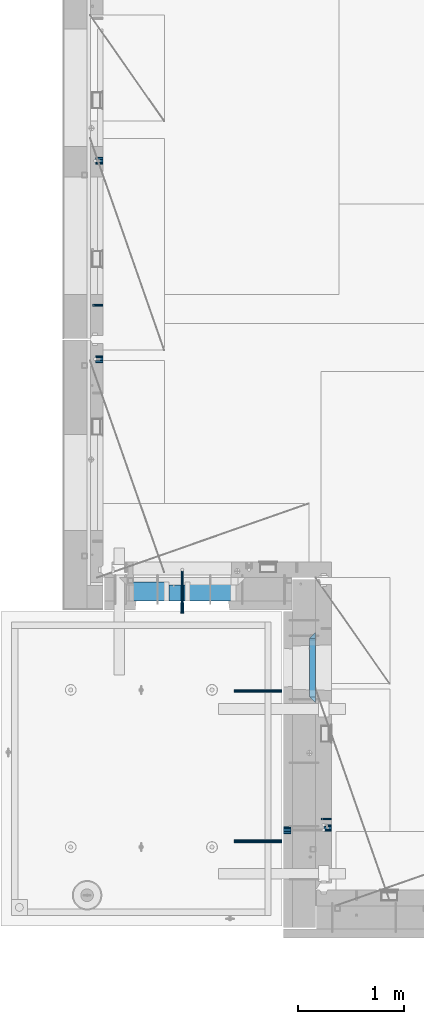
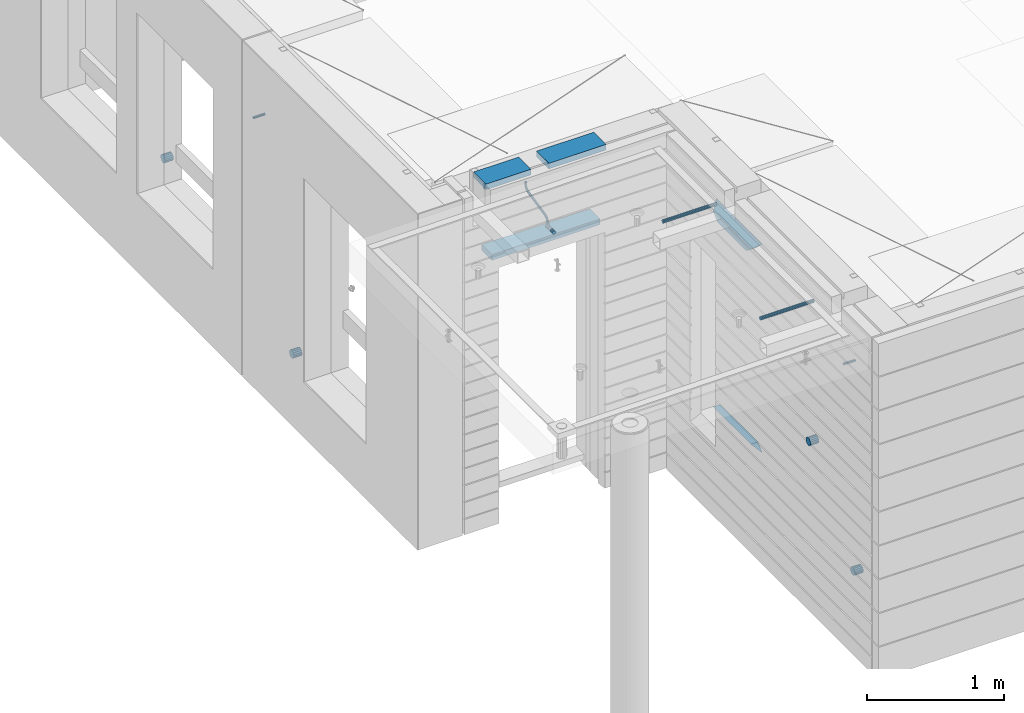
# One storey, part 139 of 349: 16 beams, 9 elements without a shape of their own.
"""IFC2X3 building model written with IfcOpenShell, lengths in millimetres."""

from ifc_helpers import new_model, si_unit, frame, origin_with_axes, place, context, subcontext, project, spatial, faceted_brep, material, type_object, element, aggregate, save


model = new_model("IFC2X3")

# Units and contexts
model_context = context("Model", 3, precision=1e-05, world=origin_with_axes())
body_context = subcontext(model_context, "Body", "Model", "MODEL_VIEW")
ifc_project = project(units=[si_unit("LENGTHUNIT", "METRE", prefix="MILLI"), si_unit("AREAUNIT", "SQUARE_METRE"), si_unit("VOLUMEUNIT", "CUBIC_METRE"), si_unit("MASSUNIT", "GRAM", prefix="KILO"), si_unit("TIMEUNIT", "SECOND"), si_unit("PLANEANGLEUNIT", "RADIAN"), si_unit("SOLIDANGLEUNIT", "STERADIAN"), si_unit("THERMODYNAMICTEMPERATUREUNIT", "DEGREE_CELSIUS"), si_unit("LUMINOUSINTENSITYUNIT", "LUMEN")], contexts=[model_context])

# Site, building, storey
site_placement = place(None, origin_with_axes())
site = spatial("IfcSite", under=ifc_project, at=site_placement, CompositionType="ELEMENT")
building_placement = place(site_placement, origin_with_axes())
building = spatial("IfcBuilding", under=site, at=building_placement, CompositionType="ELEMENT")
storey_placement = place(building_placement, origin_with_axes())
storey = spatial("IfcBuildingStorey", under=building, at=storey_placement, Name="4", CompositionType="ELEMENT", Elevation=0.0)

# Assembly, beam
assembly_1_placement = place(storey_placement, origin_with_axes())
assembly_1 = element("IfcElementAssembly", 1, at=assembly_1_placement, inside=storey, AssemblyPlace="NOTDEFINED", PredefinedType="REINFORCEMENT_UNIT")
ifc_material_1 = material(Name="TIMBER")
beam_type_1 = type_object("IfcBeamType", Name="50X150", PredefinedType="NOTDEFINED")
beam_1_placement = place(assembly_1_placement, frame((8295.00084638596, 10804.9999977209, 93070.0), z_axis=(0.0, 0.0, -1.0), x_axis=(1.0, 0.0, 0.0)))
beam_1 = element("IfcBeam", 2, at=beam_1_placement, type_object=beam_type_1, material=ifc_material_1, ObjectType="50X150", context=body_context, shape_type="Brep", body=[
    faceted_brep([(0.0, 75.0, -25.0), (1.81898940354586e-12, 75.0, 25.0), (909.997711181644, 75.0, 25.0), (909.997711181641, 75.0, -25.0), (1.81898940354586e-12, -75.0000000000009, 25.0), (909.997711181644, -75.0, 25.0), (0.0, -75.0, -25.0), (909.997711181641, -75.0, -25.0)], [[[0, 1, 2, 3]], [[1, 4, 5, 2]], [[4, 6, 7, 5]], [[6, 0, 3, 7]], [[5, 7, 3, 2]], [[6, 4, 1, 0]]]),
])

# Assemblies, beam
assembly_2_placement = place(storey_placement, origin_with_axes())
assembly_2 = element("IfcElementAssembly", 3, at=assembly_2_placement, inside=storey, AssemblyPlace="NOTDEFINED", PredefinedType="REINFORCEMENT_UNIT")
assembly_3_placement = place(assembly_2_placement, origin_with_axes())
assembly_3 = element("IfcElementAssembly", 4, at=assembly_3_placement, Name="Steel Assembly", AssemblyPlace="NOTDEFINED", PredefinedType="RIGID_FRAME")
ifc_material_2 = material(Name="STEEL/Steel_Undefined")
beam_type_2 = type_object("IfcBeamType", PredefinedType="NOTDEFINED")
beam_2_placement = place(assembly_3_placement, frame((10160.0000000031, 8669.99635449804, 92755.0), z_axis=(0.0, -1.0, 0.0), x_axis=(-1.0, 3.00000001838171e-08, 0.0)))
beam_2 = element("IfcBeam", 5, at=beam_2_placement, type_object=beam_type_2, material=ifc_material_2, Name="M16", context=body_context, shape_type="Brep", body=[
    faceted_brep([(0.0, -8.49999999999272, -1.45519152283669e-11), (0.0, -7.36121593215648, 4.24999999998545), (100.000000000262, -7.36121593215648, 4.24999999998545), (100.000000000262, -8.49999999999272, -1.45519152283669e-11), (0.0, -4.24999999998545, 7.36121593216376), (100.000000000262, -4.24999999998545, 7.36121593216376), (0.0, 1.45519152283669e-11, 8.49999999998545), (100.000000000262, 1.45519152283669e-11, 8.49999999998545), (0.0, 4.25000000001455, 7.36121593216376), (100.000000000262, 4.25000000001455, 7.36121593216376), (0.0, 7.36121593217104, 4.24999999998545), (100.000000000262, 7.36121593217104, 4.24999999998545), (0.0, 8.50000000000728, 0.0), (100.000000000262, 8.50000000000728, 0.0), (0.0, 7.36121593217104, -4.25000000001455), (100.000000000262, 7.36121593217104, -4.25000000001455), (0.0, 4.25000000000728, -7.36121593219286), (100.000000000262, 4.25000000000728, -7.36121593219286), (0.0, 7.27595761418343e-12, -8.5), (100.000000000262, 7.27595761418343e-12, -8.5), (0.0, -4.24999999999272, -7.36121593217831), (100.000000000262, -4.24999999999272, -7.36121593217831), (0.0, -7.36121593215648, -4.25), (100.000000000262, -7.36121593215648, -4.25), (0.0, -10.4999999999927, -1.45519152283669e-11), (0.0, -9.09326673972828, -5.25000000001455), (100.000000000262, -9.09326673972828, -5.25000000001455), (100.000000000262, -10.4999999999927, -1.45519152283669e-11), (0.0, -5.24999999998545, -9.09326673974283), (100.000000000262, -5.24999999998545, -9.09326673974283), (0.0, 7.27595761418343e-12, -10.5), (100.000000000262, 7.27595761418343e-12, -10.5), (0.0, 5.25000000001455, -9.09326673975738), (100.000000000262, 5.25000000001455, -9.09326673975738), (0.0, 9.09326673975011, -5.25000000001455), (100.000000000262, 9.09326673975011, -5.25000000001455), (0.0, 10.5000000000073, -1.45519152283669e-11), (100.000000000262, 10.5000000000073, -1.45519152283669e-11), (0.0, 9.09326673975011, 5.25), (100.000000000262, 9.09326673975011, 5.25), (0.0, 5.25000000000728, 9.09326673972828), (100.000000000262, 5.25000000000728, 9.09326673972828), (0.0, 1.45519152283669e-11, 10.4999999999854), (100.000000000262, 1.45519152283669e-11, 10.4999999999854), (0.0, -5.24999999999272, 9.09326673972828), (100.000000000262, -5.24999999999272, 9.09326673972828), (0.0, -9.09326673972828, 5.24999999998545), (100.000000000262, -9.09326673972828, 5.24999999998545)], [[[0, 1, 2, 3]], [[1, 4, 5, 2]], [[4, 6, 7, 5]], [[6, 8, 9, 7]], [[8, 10, 11, 9]], [[10, 12, 13, 11]], [[12, 14, 15, 13]], [[14, 16, 17, 15]], [[16, 18, 19, 17]], [[18, 20, 21, 19]], [[20, 22, 23, 21]], [[22, 0, 3, 23]], [[24, 25, 26, 27]], [[25, 28, 29, 26]], [[28, 30, 31, 29]], [[30, 32, 33, 31]], [[32, 34, 35, 33]], [[34, 36, 37, 35]], [[36, 38, 39, 37]], [[38, 40, 41, 39]], [[40, 42, 43, 41]], [[42, 44, 45, 43]], [[44, 46, 47, 45]], [[46, 24, 27, 47]], [[29, 31, 33, 35, 37, 39, 41, 43, 45, 47, 27, 26], [5, 7, 9, 11, 13, 15, 17, 19, 21, 23, 3, 2]], [[46, 44, 42, 40, 38, 36, 34, 32, 30, 28, 25, 24], [22, 20, 18, 16, 14, 12, 10, 8, 6, 4, 1, 0]]]),
])
aggregate(assembly_3, [beam_2])

assembly_4_placement = place(storey_placement, origin_with_axes())
assembly_4 = element("IfcElementAssembly", 6, at=assembly_4_placement, inside=storey, AssemblyPlace="NOTDEFINED", PredefinedType="REINFORCEMENT_UNIT")
assembly_5_placement = place(assembly_4_placement, origin_with_axes())
assembly_5 = element("IfcElementAssembly", 7, at=assembly_5_placement, Name="Steel Assembly", AssemblyPlace="NOTDEFINED", PredefinedType="RIGID_FRAME")
beam_3_placement = place(assembly_5_placement, frame((7999.99973272466, 13524.9954111548, 92755.0), z_axis=(0.0, -1.0, 0.0), x_axis=(-1.0, 3.00000001838171e-08, 0.0)))
beam_3 = element("IfcBeam", 8, at=beam_3_placement, type_object=beam_type_2, material=ifc_material_2, Name="M16", context=body_context, shape_type="Brep", body=[
    faceted_brep([(0.0, -8.49999999999272, -1.45519152283669e-11), (0.0, -7.36121593215648, 4.24999999998545), (100.000000000262, -7.36121593215648, 4.24999999998545), (100.000000000262, -8.49999999999272, -1.45519152283669e-11), (0.0, -4.24999999998545, 7.36121593216376), (100.000000000262, -4.24999999998545, 7.36121593216376), (0.0, 1.45519152283669e-11, 8.49999999998545), (100.000000000262, 1.45519152283669e-11, 8.49999999998545), (0.0, 4.25000000001455, 7.36121593216376), (100.000000000262, 4.25000000001455, 7.36121593216376), (0.0, 7.36121593217104, 4.24999999998545), (100.000000000262, 7.36121593217104, 4.24999999998545), (0.0, 8.50000000000728, 0.0), (100.000000000262, 8.50000000000728, 0.0), (0.0, 7.36121593217104, -4.25000000001455), (100.000000000262, 7.36121593217104, -4.25000000001455), (0.0, 4.25000000000728, -7.36121593219286), (100.000000000262, 4.25000000000728, -7.36121593219286), (0.0, 7.27595761418343e-12, -8.5), (100.000000000262, 7.27595761418343e-12, -8.5), (0.0, -4.24999999999272, -7.36121593217831), (100.000000000262, -4.24999999999272, -7.36121593217831), (0.0, -7.36121593215648, -4.25), (100.000000000262, -7.36121593215648, -4.25), (0.0, -10.4999999999927, -1.45519152283669e-11), (0.0, -9.09326673972828, -5.25000000001455), (100.000000000262, -9.09326673972828, -5.25000000001455), (100.000000000262, -10.4999999999927, -1.45519152283669e-11), (0.0, -5.24999999998545, -9.09326673974283), (100.000000000262, -5.24999999998545, -9.09326673974283), (0.0, 7.27595761418343e-12, -10.5), (100.000000000262, 7.27595761418343e-12, -10.5), (0.0, 5.25000000001455, -9.09326673975738), (100.000000000262, 5.25000000001455, -9.09326673975738), (0.0, 9.09326673975011, -5.25000000001455), (100.000000000262, 9.09326673975011, -5.25000000001455), (0.0, 10.5000000000073, -1.45519152283669e-11), (100.000000000262, 10.5000000000073, -1.45519152283669e-11), (0.0, 9.09326673975011, 5.25), (100.000000000262, 9.09326673975011, 5.25), (0.0, 5.25000000000728, 9.09326673972828), (100.000000000262, 5.25000000000728, 9.09326673972828), (0.0, 1.45519152283669e-11, 10.4999999999854), (100.000000000262, 1.45519152283669e-11, 10.4999999999854), (0.0, -5.24999999999272, 9.09326673972828), (100.000000000262, -5.24999999999272, 9.09326673972828), (0.0, -9.09326673972828, 5.24999999998545), (100.000000000262, -9.09326673972828, 5.24999999998545)], [[[0, 1, 2, 3]], [[1, 4, 5, 2]], [[4, 6, 7, 5]], [[6, 8, 9, 7]], [[8, 10, 11, 9]], [[10, 12, 13, 11]], [[12, 14, 15, 13]], [[14, 16, 17, 15]], [[16, 18, 19, 17]], [[18, 20, 21, 19]], [[20, 22, 23, 21]], [[22, 0, 3, 23]], [[24, 25, 26, 27]], [[25, 28, 29, 26]], [[28, 30, 31, 29]], [[30, 32, 33, 31]], [[32, 34, 35, 33]], [[34, 36, 37, 35]], [[36, 38, 39, 37]], [[38, 40, 41, 39]], [[40, 42, 43, 41]], [[42, 44, 45, 43]], [[44, 46, 47, 45]], [[46, 24, 27, 47]], [[29, 31, 33, 35, 37, 39, 41, 43, 45, 47, 27, 26], [5, 7, 9, 11, 13, 15, 17, 19, 21, 23, 3, 2]], [[46, 44, 42, 40, 38, 36, 34, 32, 30, 28, 25, 24], [22, 20, 18, 16, 14, 12, 10, 8, 6, 4, 1, 0]]]),
])
aggregate(assembly_5, [beam_3])

# Beam
ifc_material_3 = material()
beam_type_3 = type_object("IfcBeamType", Name="D20", PredefinedType="NOTDEFINED")
beam_4_placement = place(assembly_1_placement, frame((8749.01099987619, 11024.9999999788, 93407.5), z_axis=(-0.000415599999849952, -0.999999913638316, 0.0), x_axis=(-0.000120065999970847, 0.0, -0.999999992792078)))
beam_4 = element("IfcBeam", 9, at=beam_4_placement, type_object=beam_type_3, material=ifc_material_3, Name="JM20", ObjectType="D20", context=body_context, shape_type="Brep", body=[
    faceted_brep([(-0.00120059342589229, -9.99999992792982, -1.81898940354586e-12), (-0.000848598996526562, -7.07106776094588, -7.07106781186667), (20.8232838625408, -7.07356789257938, -7.07106678265518), (20.8229318684025, -10.002500059607, 1.02915510069579e-06), (0.0, 0.0, -10.0), (20.8241329547454, -0.00250013169170415, -9.99999897079033), (0.000849296484375373, 7.07106776086221, -7.07106781186667), (20.8249817580218, 7.06856762922689, -7.07106678265518), (0.00120059338223655, 9.99999992792982, 0.0), (20.8253330549196, 9.99749979629632, 1.0292096703779e-06), (0.000848598952870816, 7.07106776094406, 7.07106781186485), (20.8249810604902, 7.06856762931238, 7.07106884107452), (0.0, 0.0, 10.0), (20.8241319682711, -0.00250013157346984, 10.0000010292097), (-0.000849296528031118, -7.07106776086221, 7.07106781186485), (20.8232831650093, -7.07356789249388, 7.07106884107452), (40.7726384379348, -0.00329752151446883, -6.58672044735795), (39.7990928221261, -7.07432640138177, -3.82422098549978), (37.4482429194322, -10.0031646133011, 2.84466611986682), (35.0971847196925, -7.07413845471456, 9.51339724835998), (34.1231362304388, -0.00303172478197666, 12.2755201487289), (35.0966818461602, 7.06799715509078, 9.51302068687073), (37.4475317487959, 9.9968353670065, 2.84413358148049), (39.798589948623, 7.06780920841811, -3.82459754699994), (56.6134582193044, 7.07017615381483, 5.54543822000414), (58.4514841549535, -0.000808958311608876, 3.2647642042939), (52.1785243256745, 9.99890897559089, 11.0529357620781), (47.7446066006523, 7.06977754058425, 16.5610394651339), (45.909033913209, -0.00137268254729861, 18.8431768828377), (47.7470598488144, -7.07235779467737, 16.562502867102), (52.1819937424152, -10.0010906164425, 11.0550053250008), (56.6159114674811, -7.07195918144498, 5.54690162198131), (69.3564592543262, 7.07539916399401, 19.9729559616771), (71.8492429505422, 0.00468241929229407, 18.4335931317055), (63.3422783694841, 10.0034846953076, 23.6924434484845), (57.3297258917155, 7.07370622078452, 27.4132302674134), (54.8408735180419, 0.00228823604993522, 28.9557299626558), (57.3336572142143, -7.06842850865723, 27.4163671326332), (63.3478380990709, -9.99651403996904, 23.6968796458077), (69.3603905768541, -7.06673556544592, 19.9760928269079), (76.5777462286933, 7.08288398612058, 37.8164513940847), (79.4415723249112, 0.0125518247168657, 37.1939186795262), (69.668627354331, 10.0100419194041, 39.324584867969), (62.7614838343434, 7.07933620645599, 40.8348749661036), (59.9024266654887, 0.00753450659613009, 41.4626142320831), (62.7662527616631, -7.0627976548094, 40.8400815174773), (69.675371634672, -9.98995558832394, 39.3319480425926), (76.5825151560421, -7.05924987514118, 37.8216579454656), (129.308523154614, -6.95261720251074, 279.165101653105), (122.401379637289, -9.88332291525512, 280.675391752207), (132.167580323396, 0.11918449733821, 278.53736238712), (129.303754227207, 7.18951665872737, 279.159895101771), (122.394635352946, 10.1166745919945, 280.668028575839), (115.48749183309, 7.18596887904096, 282.178318674083), (112.628434664337, 0.114167179193828, 282.806057940068), (115.492260760511, -6.95616498219715, 282.183525225417), (137.229133330853, 0.124990099046045, 291.044246086658), (134.740500922577, -6.94638672362635, 292.587289291176), (128.728039615235, -9.87606623611646, 296.308301350005), (122.713767699344, -6.94788191340194, 300.027563864771), (120.220764095546, 0.122875581388143, 301.566383296429), (122.709396503866, 7.19425240406599, 300.02334009195), (128.721857811237, 10.1239319165488, 296.302328033165), (134.736129727069, 7.19574759383795, 292.583065518329), (144.322338774131, 7.20140934720075, 303.436489422069), (146.160972676575, 0.130265372217764, 301.156798210583), (139.887153210904, 10.1305263010836, 308.943580001445), (135.453487538296, 7.20177924807103, 314.452090976518), (133.618522976205, 0.130788491054773, 316.735211326552), (135.457156878736, -6.94035548392276, 314.455520115092), (139.892342441963, -9.86947243781106, 308.948429535751), (144.3260081146, -6.94072538479668, 303.43991856068), (156.971701508781, 7.20585774783103, 310.485308401061), (157.94687002321, 0.134410118034793, 307.72445372366), (154.620179671925, 10.1357074636107, 317.153514265787), (152.26979411245, 7.20769303758607, 323.822926758932), (151.297368814296, 0.137005609693006, 326.586694495105), (152.272537328827, -6.93444202010323, 323.825839817728), (154.624059165726, -9.86429173587385, 317.157633953042), (156.974444725187, -6.93627730985281, 310.488221459855), (171.245024905234, 7.20858667482025, 312.927536511204), (171.245873923646, 0.13695276418548, 309.999971503237), (171.244673387351, 10.1388859125454, 319.998037909079), (171.245025284385, 7.21132092570042, 327.06967187077), (171.245874459855, 0.140819578855371, 329.999971129655), (171.246723478296, -6.93081433178304, 327.072406121697), (171.247074992003, -9.86111357003938, 320.00190472537), (171.246723099146, -6.93354858266321, 312.930270762119), (187.500850232711, -6.93159678041229, 312.930269952591), (187.501202129642, -9.85916176723549, 320.001903914186), (187.50000105724, 0.13890456640911, 309.99997069378), (187.499152038683, 7.21053847703843, 312.927535701752), (187.498800520625, 10.1408377147654, 319.998037099565), (187.499152417557, 7.21327272794042, 327.069671061161), (187.500001593056, 0.142771381122657, 329.999970319972), (187.500850611585, -6.92886252950666, 327.072405311999)], [[[0, 1, 2, 3]], [[1, 4, 5, 2]], [[4, 6, 7, 5]], [[6, 8, 9, 7]], [[8, 10, 11, 9]], [[10, 12, 13, 11]], [[12, 14, 15, 13]], [[14, 0, 3, 15]], [[14, 12, 10, 8, 6, 4, 1, 0]], [[2, 5, 16, 17]], [[3, 2, 17, 18]], [[15, 3, 18, 19]], [[13, 15, 19, 20]], [[11, 13, 20, 21]], [[9, 11, 21, 22]], [[7, 9, 22, 23]], [[5, 7, 23, 16]], [[23, 24, 25, 16]], [[22, 26, 24, 23]], [[21, 27, 26, 22]], [[20, 28, 27, 21]], [[19, 29, 28, 20]], [[18, 30, 29, 19]], [[17, 31, 30, 18]], [[16, 25, 31, 17]], [[24, 32, 33, 25]], [[26, 34, 32, 24]], [[27, 35, 34, 26]], [[28, 36, 35, 27]], [[29, 37, 36, 28]], [[30, 38, 37, 29]], [[31, 39, 38, 30]], [[25, 33, 39, 31]], [[32, 40, 41, 33]], [[34, 42, 40, 32]], [[35, 43, 42, 34]], [[36, 44, 43, 35]], [[37, 45, 44, 36]], [[38, 46, 45, 37]], [[39, 47, 46, 38]], [[33, 41, 47, 39]], [[46, 47, 48, 49]], [[47, 41, 50, 48]], [[41, 40, 51, 50]], [[40, 42, 52, 51]], [[42, 43, 53, 52]], [[43, 44, 54, 53]], [[44, 45, 55, 54]], [[45, 46, 49, 55]], [[48, 50, 56, 57]], [[49, 48, 57, 58]], [[55, 49, 58, 59]], [[54, 55, 59, 60]], [[53, 54, 60, 61]], [[52, 53, 61, 62]], [[51, 52, 62, 63]], [[50, 51, 63, 56]], [[63, 64, 65, 56]], [[62, 66, 64, 63]], [[61, 67, 66, 62]], [[60, 68, 67, 61]], [[59, 69, 68, 60]], [[58, 70, 69, 59]], [[57, 71, 70, 58]], [[56, 65, 71, 57]], [[64, 72, 73, 65]], [[66, 74, 72, 64]], [[67, 75, 74, 66]], [[68, 76, 75, 67]], [[69, 77, 76, 68]], [[70, 78, 77, 69]], [[71, 79, 78, 70]], [[65, 73, 79, 71]], [[72, 80, 81, 73]], [[74, 82, 80, 72]], [[75, 83, 82, 74]], [[76, 84, 83, 75]], [[77, 85, 84, 76]], [[78, 86, 85, 77]], [[79, 87, 86, 78]], [[73, 81, 87, 79]], [[86, 87, 88, 89]], [[87, 81, 90, 88]], [[81, 80, 91, 90]], [[80, 82, 92, 91]], [[82, 83, 93, 92]], [[83, 84, 94, 93]], [[84, 85, 95, 94]], [[85, 86, 89, 95]], [[90, 91, 92, 93, 94, 95, 89, 88]]]),
])

beam_type_4 = type_object("IfcBeamType", Name="D70", PredefinedType="NOTDEFINED")
beam_5_placement = place(assembly_4_placement, frame((7999.99984877319, 14888.5021336579, 91555.0), z_axis=(0.0, 0.0, 1.0), x_axis=(-1.0, 3.00000001838171e-08, 0.0)))
beam_5 = element("IfcBeam", 10, at=beam_5_placement, type_object=beam_type_4, material=ifc_material_3, ObjectType="D70", context=body_context, shape_type="Brep", body=[
    faceted_brep([(0.0, -35.0, 0.0), (0.0, -32.3357836378964, -13.3939201327739), (70.0, -32.3357836378964, -13.3939201327739), (70.0, -35.0, 0.0), (0.0, -24.7487373415279, -24.7487373415352), (70.0, -24.7487373415279, -24.7487373415352), (0.0, -13.3939201327776, -32.3357836379), (70.0, -13.3939201327776, -32.3357836379), (0.0, 0.0, -35.0), (70.0, 0.0, -35.0), (0.0, 13.3939201327776, -32.3357836379), (70.0, 13.3939201327776, -32.3357836379), (0.0, 24.7487373415279, -24.7487373415352), (70.0, 24.7487373415279, -24.7487373415352), (0.0, 32.3357836378964, -13.3939201327739), (70.0, 32.3357836378964, -13.3939201327739), (0.0, 35.0, 0.0), (70.0, 35.0, 0.0), (0.0, 32.3357836378964, 13.3939201327739), (70.0, 32.3357836378964, 13.3939201327739), (0.0, 24.7487373415279, 24.7487373415352), (70.0, 24.7487373415279, 24.7487373415352), (0.0, 13.3939201327776, 32.3357836379), (70.0, 13.3939201327776, 32.3357836379), (0.0, 0.0, 35.0), (70.0, 0.0, 35.0), (0.0, -13.3939201327776, 32.3357836379), (70.0, -13.3939201327776, 32.3357836379), (0.0, -24.7487373415279, 24.7487373415352), (70.0, -24.7487373415279, 24.7487373415352), (0.0, -32.3357836378964, 13.3939201327739), (70.0, -32.3357836378964, 13.3939201327739)], [[[0, 1, 2, 3]], [[1, 4, 5, 2]], [[4, 6, 7, 5]], [[6, 8, 9, 7]], [[8, 10, 11, 9]], [[10, 12, 13, 11]], [[12, 14, 15, 13]], [[14, 16, 17, 15]], [[16, 18, 19, 17]], [[18, 20, 21, 19]], [[20, 22, 23, 21]], [[22, 24, 25, 23]], [[24, 26, 27, 25]], [[26, 28, 29, 27]], [[28, 30, 31, 29]], [[30, 0, 3, 31]], [[5, 7, 9, 11, 13, 15, 17, 19, 21, 23, 25, 27, 29, 31, 3, 2]], [[30, 28, 26, 24, 22, 20, 18, 16, 14, 12, 10, 8, 6, 4, 1, 0]]]),
])

aggregate(assembly_4, [beam_5, assembly_5])

# Assembly, beam
assembly_6_placement = place(storey_placement, origin_with_axes())
assembly_6 = element("IfcElementAssembly", 11, at=assembly_6_placement, inside=storey, AssemblyPlace="NOTDEFINED", PredefinedType="REINFORCEMENT_UNIT")
beam_6_placement = place(assembly_6_placement, frame((7999.99972837123, 13015.0021320444, 90955.0), z_axis=(0.0, 0.0, 1.0), x_axis=(-1.0, 3.00000001838171e-08, 0.0)))
beam_6 = element("IfcBeam", 12, at=beam_6_placement, type_object=beam_type_4, material=ifc_material_3, ObjectType="D70", context=body_context, shape_type="Brep", body=[
    faceted_brep([(0.0, -35.0, 0.0), (0.0, -32.3357836378964, -13.3939201327739), (70.0, -32.3357836378964, -13.3939201327739), (70.0, -35.0, 0.0), (0.0, -24.7487373415279, -24.7487373415352), (70.0, -24.7487373415279, -24.7487373415352), (0.0, -13.3939201327776, -32.3357836379), (70.0, -13.3939201327776, -32.3357836379), (0.0, 0.0, -35.0), (70.0, 0.0, -35.0), (0.0, 13.3939201327776, -32.3357836379), (70.0, 13.3939201327776, -32.3357836379), (0.0, 24.7487373415279, -24.7487373415352), (70.0, 24.7487373415279, -24.7487373415352), (0.0, 32.3357836378964, -13.3939201327739), (70.0, 32.3357836378964, -13.3939201327739), (0.0, 35.0, 0.0), (70.0, 35.0, 0.0), (0.0, 32.3357836378964, 13.3939201327739), (70.0, 32.3357836378964, 13.3939201327739), (0.0, 24.7487373415279, 24.7487373415352), (70.0, 24.7487373415279, 24.7487373415352), (0.0, 13.3939201327776, 32.3357836379), (70.0, 13.3939201327776, 32.3357836379), (0.0, 0.0, 35.0), (70.0, 0.0, 35.0), (0.0, -13.3939201327776, 32.3357836379), (70.0, -13.3939201327776, 32.3357836379), (0.0, -24.7487373415279, 24.7487373415352), (70.0, -24.7487373415279, 24.7487373415352), (0.0, -32.3357836378964, 13.3939201327739), (70.0, -32.3357836378964, 13.3939201327739)], [[[0, 1, 2, 3]], [[1, 4, 5, 2]], [[4, 6, 7, 5]], [[6, 8, 9, 7]], [[8, 10, 11, 9]], [[10, 12, 13, 11]], [[12, 14, 15, 13]], [[14, 16, 17, 15]], [[16, 18, 19, 17]], [[18, 20, 21, 19]], [[20, 22, 23, 21]], [[22, 24, 25, 23]], [[24, 26, 27, 25]], [[26, 28, 29, 27]], [[28, 30, 31, 29]], [[30, 0, 3, 31]], [[5, 7, 9, 11, 13, 15, 17, 19, 21, 23, 25, 27, 29, 31, 3, 2]], [[30, 28, 26, 24, 22, 20, 18, 16, 14, 12, 10, 8, 6, 4, 1, 0]]]),
])
aggregate(assembly_6, [beam_6])

# Beam
beam_7_placement = place(assembly_2_placement, frame((10160.0000000031, 8585.00172002957, 90954.9999999969), z_axis=(0.0, 0.0, 1.0), x_axis=(-1.0, 3.00000001838171e-08, 0.0)))
beam_7 = element("IfcBeam", 13, at=beam_7_placement, type_object=beam_type_4, material=ifc_material_3, ObjectType="D70", context=body_context, shape_type="Brep", body=[
    faceted_brep([(0.0, -35.0, 0.0), (0.0, -32.3357836378964, -13.3939201327739), (70.0, -32.3357836378964, -13.3939201327739), (70.0, -35.0, 0.0), (0.0, -24.7487373415279, -24.7487373415352), (70.0, -24.7487373415279, -24.7487373415352), (0.0, -13.3939201327776, -32.3357836379), (70.0, -13.3939201327776, -32.3357836379), (0.0, 0.0, -35.0), (70.0, 0.0, -35.0), (0.0, 13.3939201327776, -32.3357836379), (70.0, 13.3939201327776, -32.3357836379), (0.0, 24.7487373415279, -24.7487373415352), (70.0, 24.7487373415279, -24.7487373415352), (0.0, 32.3357836378964, -13.3939201327739), (70.0, 32.3357836378964, -13.3939201327739), (0.0, 35.0, 0.0), (70.0, 35.0, 0.0), (0.0, 32.3357836378964, 13.3939201327739), (70.0, 32.3357836378964, 13.3939201327739), (0.0, 24.7487373415279, 24.7487373415352), (70.0, 24.7487373415279, 24.7487373415352), (0.0, 13.3939201327776, 32.3357836379), (70.0, 13.3939201327776, 32.3357836379), (0.0, 0.0, 35.0), (70.0, 0.0, 35.0), (0.0, -13.3939201327776, 32.3357836379), (70.0, -13.3939201327776, 32.3357836379), (0.0, -24.7487373415279, 24.7487373415352), (70.0, -24.7487373415279, 24.7487373415352), (0.0, -32.3357836378964, 13.3939201327739), (70.0, -32.3357836378964, 13.3939201327739)], [[[0, 1, 2, 3]], [[1, 4, 5, 2]], [[4, 6, 7, 5]], [[6, 8, 9, 7]], [[8, 10, 11, 9]], [[10, 12, 13, 11]], [[12, 14, 15, 13]], [[14, 16, 17, 15]], [[16, 18, 19, 17]], [[18, 20, 21, 19]], [[20, 22, 23, 21]], [[22, 24, 25, 23]], [[24, 26, 27, 25]], [[26, 28, 29, 27]], [[28, 30, 31, 29]], [[30, 0, 3, 31]], [[5, 7, 9, 11, 13, 15, 17, 19, 21, 23, 25, 27, 29, 31, 3, 2]], [[30, 28, 26, 24, 22, 20, 18, 16, 14, 12, 10, 8, 6, 4, 1, 0]]]),
])

beam_8_placement = place(assembly_2_placement, frame((9705.0, 8564.99633327303, 92255.0), z_axis=(0.0, 0.0, 1.0), x_axis=(1.0, 0.0, 0.0)))
beam_8 = element("IfcBeam", 14, at=beam_8_placement, type_object=beam_type_4, material=ifc_material_3, ObjectType="D70", context=body_context, shape_type="Brep", body=[
    faceted_brep([(0.0, -35.0, 0.0), (0.0, -32.3357836378964, -13.3939201327739), (70.0, -32.3357836378964, -13.3939201327739), (70.0, -35.0, 0.0), (0.0, -24.7487373415279, -24.7487373415352), (70.0, -24.7487373415279, -24.7487373415352), (0.0, -13.3939201327776, -32.3357836379), (70.0, -13.3939201327776, -32.3357836379), (0.0, 0.0, -35.0), (70.0, 0.0, -35.0), (0.0, 13.3939201327776, -32.3357836379), (70.0, 13.3939201327776, -32.3357836379), (0.0, 24.7487373415279, -24.7487373415352), (70.0, 24.7487373415279, -24.7487373415352), (0.0, 32.3357836378964, -13.3939201327739), (70.0, 32.3357836378964, -13.3939201327739), (0.0, 35.0, 0.0), (70.0, 35.0, 0.0), (0.0, 32.3357836378964, 13.3939201327739), (70.0, 32.3357836378964, 13.3939201327739), (0.0, 24.7487373415279, 24.7487373415352), (70.0, 24.7487373415279, 24.7487373415352), (0.0, 13.3939201327776, 32.3357836379), (70.0, 13.3939201327776, 32.3357836379), (0.0, 0.0, 35.0), (70.0, 0.0, 35.0), (0.0, -13.3939201327776, 32.3357836379), (70.0, -13.3939201327776, 32.3357836379), (0.0, -24.7487373415279, 24.7487373415352), (70.0, -24.7487373415279, 24.7487373415352), (0.0, -32.3357836378964, 13.3939201327739), (70.0, -32.3357836378964, 13.3939201327739)], [[[0, 1, 2, 3]], [[1, 4, 5, 2]], [[4, 6, 7, 5]], [[6, 8, 9, 7]], [[8, 10, 11, 9]], [[10, 12, 13, 11]], [[12, 14, 15, 13]], [[14, 16, 17, 15]], [[16, 18, 19, 17]], [[18, 20, 21, 19]], [[20, 22, 23, 21]], [[22, 24, 25, 23]], [[24, 26, 27, 25]], [[26, 28, 29, 27]], [[28, 30, 31, 29]], [[30, 0, 3, 31]], [[5, 7, 9, 11, 13, 15, 17, 19, 21, 23, 25, 27, 29, 31, 3, 2]], [[30, 28, 26, 24, 22, 20, 18, 16, 14, 12, 10, 8, 6, 4, 1, 0]]]),
])

beam_type_5 = type_object("IfcBeamType", Name="D30", PredefinedType="NOTDEFINED")
beam_9_placement = place(assembly_1_placement, frame((8749.00366673359, 10610.0, 93205.0), z_axis=(0.0, 0.0, 1.0), x_axis=(0.0, 1.0, 0.0)))
beam_9 = element("IfcBeam", 15, at=beam_9_placement, type_object=beam_type_5, material=ifc_material_3, Name="AJ 10.20", ObjectType="D30", context=body_context, shape_type="Brep", body=[
    faceted_brep([(0.0, -15.0, 0.0), (0.0, -12.9903810567666, -7.5), (105.0, -12.9903810567666, -7.5), (105.0, -15.0, 0.0), (0.0, -7.5, -12.9903810567666), (105.0, -7.5, -12.990381056763), (0.0, 0.0, -15.0), (105.0, 0.0, -15.0), (0.0, 7.5, -12.9903810567666), (105.0, 7.5, -12.990381056763), (0.0, 12.9903810567666, -7.5), (105.0, 12.9903810567666, -7.5), (0.0, 15.0, 0.0), (105.0, 15.0, 0.0), (0.0, 12.9903810567666, 7.5), (105.0, 12.9903810567666, 7.5), (0.0, 7.5, 12.9903810567666), (105.0, 7.5, 12.990381056763), (0.0, 0.0, 15.0), (105.0, 0.0, 15.0), (0.0, -7.5, 12.9903810567666), (105.0, -7.5, 12.990381056763), (0.0, -12.9903810567666, 7.5), (105.0, -12.9903810567666, 7.5)], [[[0, 1, 2, 3]], [[1, 4, 5, 2]], [[4, 6, 7, 5]], [[6, 8, 9, 7]], [[8, 10, 11, 9]], [[10, 12, 13, 11]], [[12, 14, 15, 13]], [[14, 16, 17, 15]], [[16, 18, 19, 17]], [[18, 20, 21, 19]], [[20, 22, 23, 21]], [[22, 0, 3, 23]], [[5, 7, 9, 11, 13, 15, 17, 19, 21, 23, 3, 2]], [[22, 20, 18, 16, 14, 12, 10, 8, 6, 4, 1, 0]]]),
])

# Assemblies, beams
assembly_7_placement = place(storey_placement, origin_with_axes())
assembly_7 = element("IfcElementAssembly", 16, at=assembly_7_placement, inside=storey, AssemblyPlace="NOTDEFINED", PredefinedType="REINFORCEMENT_UNIT")
assembly_8_placement = place(assembly_7_placement, origin_with_axes())
assembly_8 = element("IfcElementAssembly", 17, at=assembly_8_placement, Name="Steel Assembly", AssemblyPlace="NOTDEFINED", PredefinedType="RIGID_FRAME")
ifc_material_4 = material(Name="STEEL/S235JR")
beam_10_placement = place(assembly_8_placement, frame((9689.97466054669, 8459.99985675633, 93575.0), z_axis=(0.0, 0.0, 1.0), x_axis=(-1.0, 3.00000001838171e-08, 0.0)))
beam_10 = element("IfcBeam", 18, at=beam_10_placement, type_object=beam_type_5, material=ifc_material_4, Name="Rd30", ObjectType="D30", context=body_context, shape_type="Brep", body=[
    faceted_brep([(0.0, -15.0, 0.0), (0.0, -12.9903810567666, -7.5), (450.0, -12.9903810567666, -7.5), (450.0, -15.0, 0.0), (0.0, -7.5, -12.9903810567666), (450.0, -7.5, -12.990381056763), (0.0, 0.0, -15.0), (450.0, 0.0, -15.0), (0.0, 7.5, -12.9903810567666), (450.0, 7.5, -12.990381056763), (0.0, 12.9903810567666, -7.5), (450.0, 12.9903810567666, -7.5), (0.0, 15.0, 0.0), (450.0, 15.0, 0.0), (0.0, 12.9903810567666, 7.5), (450.0, 12.9903810567666, 7.5), (0.0, 7.5, 12.9903810567666), (450.0, 7.5, 12.990381056763), (0.0, 0.0, 15.0), (450.0, 0.0, 15.0), (0.0, -7.5, 12.9903810567666), (450.0, -7.5, 12.990381056763), (0.0, -12.9903810567666, 7.5), (450.0, -12.9903810567666, 7.5)], [[[0, 1, 2, 3]], [[1, 4, 5, 2]], [[4, 6, 7, 5]], [[6, 8, 9, 7]], [[8, 10, 11, 9]], [[10, 12, 13, 11]], [[12, 14, 15, 13]], [[14, 16, 17, 15]], [[16, 18, 19, 17]], [[18, 20, 21, 19]], [[20, 22, 23, 21]], [[22, 0, 3, 23]], [[5, 7, 9, 11, 13, 15, 17, 19, 21, 23, 3, 2]], [[22, 20, 18, 16, 14, 12, 10, 8, 6, 4, 1, 0]]]),
])
aggregate(assembly_8, [beam_10])
assembly_9_placement = place(assembly_7_placement, origin_with_axes())
assembly_9 = element("IfcElementAssembly", 19, at=assembly_9_placement, Name="Steel Assembly", AssemblyPlace="NOTDEFINED", PredefinedType="RIGID_FRAME")
aggregate(assembly_7, [assembly_8, assembly_9])
beam_11_placement = place(assembly_9_placement, frame((9689.98478639016, 9879.99985700661, 93575.0), z_axis=(0.0, 0.0, 1.0), x_axis=(-1.0, 3.00000001838171e-08, 0.0)))
beam_11 = element("IfcBeam", 20, at=beam_11_placement, type_object=beam_type_5, material=ifc_material_4, Name="Rd30", ObjectType="D30", context=body_context, shape_type="Brep", body=[
    faceted_brep([(0.0, -15.0, 0.0), (0.0, -12.9903810567666, -7.5), (450.0, -12.9903810567666, -7.5), (450.0, -15.0, 0.0), (0.0, -7.5, -12.9903810567666), (450.0, -7.5, -12.990381056763), (0.0, 0.0, -15.0), (450.0, 0.0, -15.0), (0.0, 7.5, -12.9903810567666), (450.0, 7.5, -12.990381056763), (0.0, 12.9903810567666, -7.5), (450.0, 12.9903810567666, -7.5), (0.0, 15.0, 0.0), (450.0, 15.0, 0.0), (0.0, 12.9903810567666, 7.5), (450.0, 12.9903810567666, 7.5), (0.0, 7.5, 12.9903810567666), (450.0, 7.5, 12.990381056763), (0.0, 0.0, 15.0), (450.0, 0.0, 15.0), (0.0, -7.5, 12.9903810567666), (450.0, -7.5, 12.990381056763), (0.0, -12.9903810567666, 7.5), (450.0, -12.9903810567666, 7.5)], [[[0, 1, 2, 3]], [[1, 4, 5, 2]], [[4, 6, 7, 5]], [[6, 8, 9, 7]], [[8, 10, 11, 9]], [[10, 12, 13, 11]], [[12, 14, 15, 13]], [[14, 16, 17, 15]], [[16, 18, 19, 17]], [[18, 20, 21, 19]], [[20, 22, 23, 21]], [[22, 0, 3, 23]], [[5, 7, 9, 11, 13, 15, 17, 19, 21, 23, 3, 2]], [[22, 20, 18, 16, 14, 12, 10, 8, 6, 4, 1, 0]]]),
])
aggregate(assembly_9, [beam_11])

# Beam
ifc_material_5 = material(Name="CONCRETE/C25/30")
beam_type_6 = type_object("IfcBeamType", PredefinedType="NOTDEFINED")
beam_12_placement = place(assembly_2_placement, frame((9980.0, 10435.0000000021, 93145.0), z_axis=(0.0, 0.0, -1.0), x_axis=(0.0, -1.0, 0.0)))
beam_12 = element("IfcBeam", 21, at=beam_12_placement, type_object=beam_type_6, material=ifc_material_5, Name="SK", context=body_context, shape_type="Brep", body=[
    faceted_brep([(60.0000000000073, 30.0, 30.0), (0.0, -30.0, -30.0), (60.0000000000073, -30.0, 30.0), (609.999618530263, -30.0, 30.0), (609.999618530263, 30.0, 30.0), (669.999575761092, -30.0, -30.0)], [[[0, 1, 2]], [[0, 2, 3, 4]], [[1, 0, 4, 5]], [[2, 1, 5, 3]], [[5, 4, 3]]]),
])

beam_13_placement = place(assembly_2_placement, frame((9980.00000000155, 10375.0000000021, 93085.0), z_axis=(0.0, 0.0, -1.0), x_axis=(0.0, -1.0, 0.0)))
beam_13 = element("IfcBeam", 22, at=beam_13_placement, type_object=beam_type_6, material=ifc_material_5, Name="SK", context=body_context, shape_type="Brep", body=[
    faceted_brep([(65.6752514367672, 29.999999998452, 26.2930726477352), (0.0, 30.0, -30.0), (0.0, -30.0, -30.0), (64.0536298152292, -29.999999998452, 24.9031112581433), (64.0536298152292, -29.999999998452, 24.0540540541406), (65.6752514367672, 29.999999998452, 25.6756756756804), (485.94556447622, -30.0, 24.0540540540533), (484.323942854597, 30.0, 25.6756756756804), (485.94556447622, -30.0, 24.9034748914273), (484.323942854597, 30.0, 26.293436281092), (549.999575761092, 29.999999998452, -30.0), (549.999575761092, -29.999999998452, -30.0)], [[[0, 1, 2, 3]], [[4, 5, 0, 3]], [[6, 7, 5, 4]], [[7, 6, 8, 9]], [[1, 0, 5, 7, 9, 10]], [[2, 1, 10, 11]], [[6, 4, 3, 2, 11, 8]], [[8, 11, 10, 9]]]),
])

beam_14_placement = place(assembly_2_placement, frame((9980.0, 9765.00042424099, 91350.0), z_axis=(0.0, 0.0, 1.0), x_axis=(0.0, 1.0, 0.0)))
beam_14 = element("IfcBeam", 23, at=beam_14_placement, type_object=beam_type_6, material=ifc_material_5, Name="SK", context=body_context, shape_type="Brep", body=[
    faceted_brep([(669.999575761092, -30.0, -30.0), (609.999618530263, 30.0, 30.0), (609.999618530263, -30.0, 30.0), (60.0000000000073, -30.0, 30.0), (0.0, -30.0, -30.0), (60.0000000000073, 30.0, 30.0)], [[[0, 1, 2]], [[3, 4, 0, 2]], [[4, 5, 1, 0]], [[5, 3, 2, 1]], [[5, 4, 3]]]),
])

aggregate(assembly_2, [assembly_3, beam_7, beam_8, beam_12, beam_13, beam_14])

beam_type_7 = type_object("IfcBeamType", PredefinedType="NOTDEFINED")
beam_15_placement = place(assembly_1_placement, frame((8625.00003814753, 10820.0, 93715.0), z_axis=(0.0, 0.0, 1.0), x_axis=(-1.0, 3.00000001838171e-08, 0.0)))
beam_15 = element("IfcBeam", 24, at=beam_15_placement, type_object=beam_type_7, material=ifc_material_1, context=body_context, shape_type="Brep", body=[
    faceted_brep([(0.0, 90.0, -25.0), (0.0, 90.0, 25.0), (379.99983857082, 90.0, 25.0), (379.99983857082, 90.0, -25.0), (0.0, -90.0, 25.0), (379.99983857082, -90.0, 25.0), (0.0, -90.0, -25.0), (379.99983857082, -90.0, -25.0)], [[[0, 1, 2, 3]], [[1, 4, 5, 2]], [[4, 6, 7, 5]], [[6, 0, 3, 7]], [[5, 7, 3, 2]], [[6, 4, 1, 0]]]),
])

beam_16_placement = place(assembly_1_placement, frame((9255.00003814753, 10820.0, 93715.0), z_axis=(0.0, 0.0, 1.0), x_axis=(-1.0, 3.00000001838171e-08, 0.0)))
beam_16 = element("IfcBeam", 25, at=beam_16_placement, type_object=beam_type_7, material=ifc_material_1, context=body_context, shape_type="Brep", body=[
    faceted_brep([(0.0, 90.0, -25.0), (0.0, 90.0, 25.0), (480.99983857082, 90.0, 25.0), (480.99983857082, 90.0, -25.0), (0.0, -90.0, 25.0), (480.99983857082, -90.0, 25.0), (0.0, -90.0, -25.0), (480.99983857082, -90.0, -25.0)], [[[0, 1, 2, 3]], [[1, 4, 5, 2]], [[4, 6, 7, 5]], [[6, 0, 3, 7]], [[5, 7, 3, 2]], [[6, 4, 1, 0]]]),
])

aggregate(assembly_1, [beam_15, beam_9, beam_4, beam_16, beam_1])

save(model, "model.ifc")
